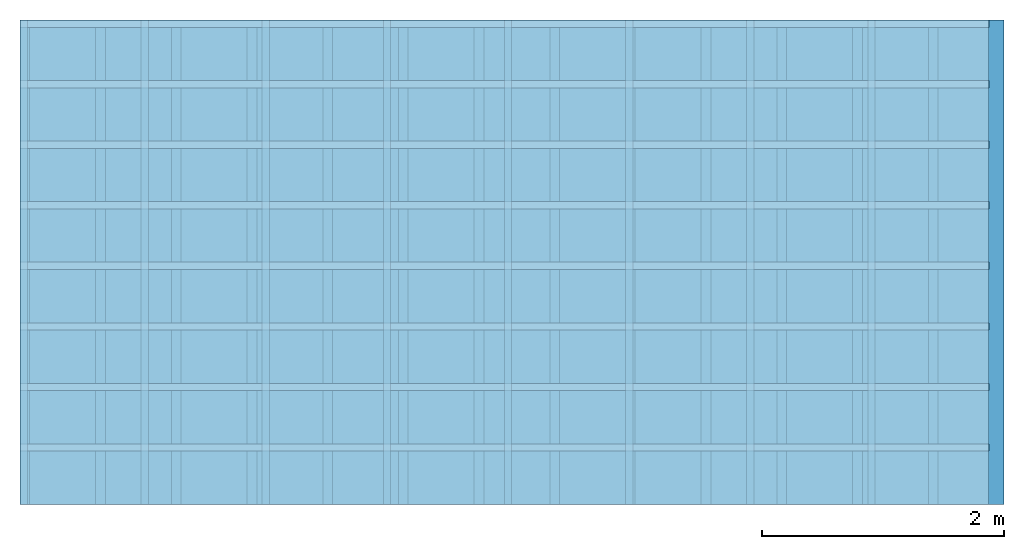
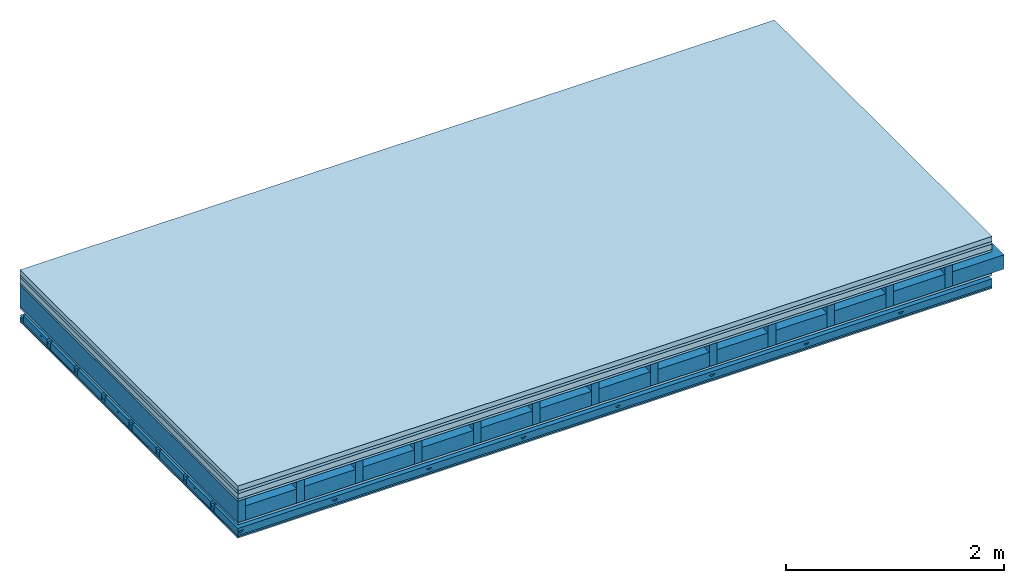
# One storey: 7 plates, 5 members, 1 element without a shape of its own.
"""IFC4 building model written with IfcOpenShell, lengths in metres."""

from ifc_helpers import new_model, si_unit, derived_unit, direction, frame, frame_2d, origin, origin_with_axes, place, context, project, spatial, polyline, rectangle, outline, extrude, material, layer, layer_set, type_object, element, aggregate, save


model = new_model("IFC4")

# Units and contexts
plan_context = context("Plan", 3, precision=1e-05, world=origin(), true_north=direction((0.0, 1.0)))
model_context = context("Model", 3, precision=1e-05, world=origin(), true_north=direction((0.0, 1.0)))
ifc_project = project(units=[si_unit("LENGTHUNIT", "METRE"), derived_unit("SOUNDPRESSUREUNIT", [(si_unit("PRESSUREUNIT", "PASCAL", prefix="MICRO"), 0)]), si_unit("ENERGYUNIT", "JOULE", prefix="MEGA"), si_unit("MASSUNIT", "GRAM", prefix="KILO"), derived_unit("THERMALTRANSMITTANCEUNIT", [(si_unit("POWERUNIT", "WATT"), 1), (si_unit("AREAUNIT", "SQUARE_METRE"), -1), (si_unit("THERMODYNAMICTEMPERATUREUNIT", "KELVIN"), -1)]), derived_unit("AREADENSITYUNIT", [(si_unit("MASSUNIT", "GRAM", prefix="KILO"), 1), (si_unit("AREAUNIT", "SQUARE_METRE"), -1)]), derived_unit("USERDEFINED", [(si_unit("ENERGYUNIT", "JOULE", prefix="MEGA"), 1), (si_unit("AREAUNIT", "SQUARE_METRE"), -1)])], contexts=[plan_context, model_context])

# Site, building, storey
site = spatial("IfcSite", under=ifc_project)
building_placement = place(None, origin())
building = spatial("IfcBuilding", under=site, at=building_placement)
storey_placement = place(building_placement, origin())
storey = spatial("IfcBuildingStorey", under=building, at=storey_placement)

# Slab, members, plates
ifc_material_1 = material(Category="04.005")
ifc_layer_1 = layer(ifc_material_1, 0.055, Name="On-material")
ifc_material_2 = material()
ifc_layer_2 = layer(ifc_material_2, 0.03, Name="Impact sound insulation")
ifc_material_3 = material(Name="Cement panels, glued on sub-floor", Category="02.007")
ifc_layer_3 = layer(ifc_material_3, 0.06, Name="on Supporting structure")
ifc_material_4 = material(Category="07.001")
ifc_layer_4 = layer(ifc_material_4, 0.025, Name="Sub-floor")
ifc_material_5 = material(Name="Rigid, of the art")
ifc_layer_5 = layer(ifc_material_5, 0.0, Name="Bond")
ifc_layer_6 = layer(None, 0.24, Name="Supporting structure")
ifc_layer_7 = layer(ifc_material_5, 0.0, Name="Bond")
ifc_layer_8 = layer(ifc_material_4, 0.025, Name="Lower layer 1")
ifc_layer_9 = layer(None, 0.093, Name="Coupling")
ifc_layer_10 = layer(None, 0.027, Name="Battens / profiles")
ifc_material_6 = material(Name="Plasterboard type A", Category="03.008")
ifc_layer_11 = layer(ifc_material_6, 0.015, Name="Ceiling covering 1st layer")
ifc_layer_12 = layer(ifc_material_6, 0.015, Name="Ceiling covering layer 2")
ifc_material_7 = material(Name="joints", Category="04.017")
ifc_layer_13 = layer(ifc_material_7, 0.0, Name="Surface / treatment")
ifc_layer_set = layer_set([ifc_layer_1, ifc_layer_2, ifc_layer_3, ifc_layer_4, ifc_layer_5, ifc_layer_6, ifc_layer_7, ifc_layer_8, ifc_layer_9, ifc_layer_10, ifc_layer_11, ifc_layer_12, ifc_layer_13])
slab_type = type_object("IfcSlabType", Name="A0585", PredefinedType="NOTDEFINED", material=ifc_layer_set)
slab_placement = place(None, frame((0.0, 0.0, 0.0), z_axis=(0.0, 0.0, -1.0), x_axis=(1.0, 0.0, 0.0)))
slab = element("IfcSlab", 1, at=slab_placement, inside=storey, type_object=slab_type, material=ifc_layer_set, Name="Slab #1")
ifc_material_8 = material()
member_1_placement = place(slab_placement, origin())
member_1 = element("IfcMember", 2, at=member_1_placement, material=ifc_material_8, Name="Supporting structure", context=plan_context, shape_type="SweptSolid", body=[
    extrude(rectangle(XDim=0.08, YDim=0.24, at=frame_2d((0.04, 0.12), x_axis=(1.0, 0.0))), frame((0.0, 4.0, 0.17), z_axis=(0.0, -1.0, 0.0), x_axis=(1.0, 0.0, 0.0)), (0.0, 0.0, 1.0), 4.0),
    extrude(rectangle(XDim=0.08, YDim=0.24, at=frame_2d((0.04, 0.12), x_axis=(1.0, 0.0))), frame((0.625, 4.0, 0.17), z_axis=(0.0, -1.0, 0.0), x_axis=(1.0, 0.0, 0.0)), (0.0, 0.0, 1.0), 4.0),
    extrude(rectangle(XDim=0.08, YDim=0.24, at=frame_2d((0.04, 0.12), x_axis=(1.0, 0.0))), frame((1.25, 4.0, 0.17), z_axis=(0.0, -1.0, 0.0), x_axis=(1.0, 0.0, 0.0)), (0.0, 0.0, 1.0), 4.0),
    extrude(rectangle(XDim=0.08, YDim=0.24, at=frame_2d((0.04, 0.12), x_axis=(1.0, 0.0))), frame((1.875, 4.0, 0.17), z_axis=(0.0, -1.0, 0.0), x_axis=(1.0, 0.0, 0.0)), (0.0, 0.0, 1.0), 4.0),
    extrude(rectangle(XDim=0.08, YDim=0.24, at=frame_2d((0.04, 0.12), x_axis=(1.0, 0.0))), frame((2.5, 4.0, 0.17), z_axis=(0.0, -1.0, 0.0), x_axis=(1.0, 0.0, 0.0)), (0.0, 0.0, 1.0), 4.0),
    extrude(rectangle(XDim=0.08, YDim=0.24, at=frame_2d((0.04, 0.12), x_axis=(1.0, 0.0))), frame((3.125, 4.0, 0.17), z_axis=(0.0, -1.0, 0.0), x_axis=(1.0, 0.0, 0.0)), (0.0, 0.0, 1.0), 4.0),
    extrude(rectangle(XDim=0.08, YDim=0.24, at=frame_2d((0.04, 0.12), x_axis=(1.0, 0.0))), frame((3.75, 4.0, 0.17), z_axis=(0.0, -1.0, 0.0), x_axis=(1.0, 0.0, 0.0)), (0.0, 0.0, 1.0), 4.0),
    extrude(rectangle(XDim=0.08, YDim=0.24, at=frame_2d((0.04, 0.12), x_axis=(1.0, 0.0))), frame((4.375, 4.0, 0.17), z_axis=(0.0, -1.0, 0.0), x_axis=(1.0, 0.0, 0.0)), (0.0, 0.0, 1.0), 4.0),
    extrude(rectangle(XDim=0.08, YDim=0.24, at=frame_2d((0.04, 0.12), x_axis=(1.0, 0.0))), frame((5.0, 4.0, 0.17), z_axis=(0.0, -1.0, 0.0), x_axis=(1.0, 0.0, 0.0)), (0.0, 0.0, 1.0), 4.0),
    extrude(rectangle(XDim=0.08, YDim=0.24, at=frame_2d((0.04, 0.12), x_axis=(1.0, 0.0))), frame((5.625, 4.0, 0.17), z_axis=(0.0, -1.0, 0.0), x_axis=(1.0, 0.0, 0.0)), (0.0, 0.0, 1.0), 4.0),
    extrude(rectangle(XDim=0.08, YDim=0.24, at=frame_2d((0.04, 0.12), x_axis=(1.0, 0.0))), frame((6.25, 4.0, 0.17), z_axis=(0.0, -1.0, 0.0), x_axis=(1.0, 0.0, 0.0)), (0.0, 0.0, 1.0), 4.0),
    extrude(rectangle(XDim=0.08, YDim=0.24, at=frame_2d((0.04, 0.12), x_axis=(1.0, 0.0))), frame((6.875, 4.0, 0.17), z_axis=(0.0, -1.0, 0.0), x_axis=(1.0, 0.0, 0.0)), (0.0, 0.0, 1.0), 4.0),
    extrude(rectangle(XDim=0.08, YDim=0.24, at=frame_2d((0.04, 0.12), x_axis=(1.0, 0.0))), frame((7.5, 4.0, 0.17), z_axis=(0.0, -1.0, 0.0), x_axis=(1.0, 0.0, 0.0)), (0.0, 0.0, 1.0), 4.0),
])
ifc_material_9 = material()
member_2_placement = place(slab_placement, origin())
member_2 = element("IfcMember", 3, at=member_2_placement, material=ifc_material_9, Name="Cavity", context=plan_context, shape_type="SweptSolid", body=[
    extrude(rectangle(XDim=0.545, YDim=0.16, at=frame_2d((0.2725, 0.08), x_axis=(1.0, 0.0))), frame((0.08, 4.0, 0.25), z_axis=(0.0, -1.0, 0.0), x_axis=(1.0, 0.0, 0.0)), (0.0, 0.0, 1.0), 4.0),
    extrude(rectangle(XDim=0.545, YDim=0.16, at=frame_2d((0.2725, 0.08), x_axis=(1.0, 0.0))), frame((0.705, 4.0, 0.25), z_axis=(0.0, -1.0, 0.0), x_axis=(1.0, 0.0, 0.0)), (0.0, 0.0, 1.0), 4.0),
    extrude(rectangle(XDim=0.545, YDim=0.16, at=frame_2d((0.2725, 0.08), x_axis=(1.0, 0.0))), frame((1.33, 4.0, 0.25), z_axis=(0.0, -1.0, 0.0), x_axis=(1.0, 0.0, 0.0)), (0.0, 0.0, 1.0), 4.0),
    extrude(rectangle(XDim=0.545, YDim=0.16, at=frame_2d((0.2725, 0.08), x_axis=(1.0, 0.0))), frame((1.955, 4.0, 0.25), z_axis=(0.0, -1.0, 0.0), x_axis=(1.0, 0.0, 0.0)), (0.0, 0.0, 1.0), 4.0),
    extrude(rectangle(XDim=0.545, YDim=0.16, at=frame_2d((0.2725, 0.08), x_axis=(1.0, 0.0))), frame((2.58, 4.0, 0.25), z_axis=(0.0, -1.0, 0.0), x_axis=(1.0, 0.0, 0.0)), (0.0, 0.0, 1.0), 4.0),
    extrude(rectangle(XDim=0.545, YDim=0.16, at=frame_2d((0.2725, 0.08), x_axis=(1.0, 0.0))), frame((3.205, 4.0, 0.25), z_axis=(0.0, -1.0, 0.0), x_axis=(1.0, 0.0, 0.0)), (0.0, 0.0, 1.0), 4.0),
    extrude(rectangle(XDim=0.545, YDim=0.16, at=frame_2d((0.2725, 0.08), x_axis=(1.0, 0.0))), frame((3.83, 4.0, 0.25), z_axis=(0.0, -1.0, 0.0), x_axis=(1.0, 0.0, 0.0)), (0.0, 0.0, 1.0), 4.0),
    extrude(rectangle(XDim=0.545, YDim=0.16, at=frame_2d((0.2725, 0.08), x_axis=(1.0, 0.0))), frame((4.455, 4.0, 0.25), z_axis=(0.0, -1.0, 0.0), x_axis=(1.0, 0.0, 0.0)), (0.0, 0.0, 1.0), 4.0),
    extrude(rectangle(XDim=0.545, YDim=0.16, at=frame_2d((0.2725, 0.08), x_axis=(1.0, 0.0))), frame((5.08, 4.0, 0.25), z_axis=(0.0, -1.0, 0.0), x_axis=(1.0, 0.0, 0.0)), (0.0, 0.0, 1.0), 4.0),
    extrude(rectangle(XDim=0.545, YDim=0.16, at=frame_2d((0.2725, 0.08), x_axis=(1.0, 0.0))), frame((5.705, 4.0, 0.25), z_axis=(0.0, -1.0, 0.0), x_axis=(1.0, 0.0, 0.0)), (0.0, 0.0, 1.0), 4.0),
    extrude(rectangle(XDim=0.545, YDim=0.16, at=frame_2d((0.2725, 0.08), x_axis=(1.0, 0.0))), frame((6.33, 4.0, 0.25), z_axis=(0.0, -1.0, 0.0), x_axis=(1.0, 0.0, 0.0)), (0.0, 0.0, 1.0), 4.0),
    extrude(rectangle(XDim=0.545, YDim=0.16, at=frame_2d((0.2725, 0.08), x_axis=(1.0, 0.0))), frame((6.955, 4.0, 0.25), z_axis=(0.0, -1.0, 0.0), x_axis=(1.0, 0.0, 0.0)), (0.0, 0.0, 1.0), 4.0),
    extrude(rectangle(XDim=0.545, YDim=0.16, at=frame_2d((0.2725, 0.08), x_axis=(1.0, 0.0))), frame((7.58, 4.0, 0.25), z_axis=(0.0, -1.0, 0.0), x_axis=(1.0, 0.0, 0.0)), (0.0, 0.0, 1.0), 4.0),
])
ifc_material_10 = material()
member_3_placement = place(slab_placement, origin())
member_3 = element("IfcMember", 4, at=member_3_placement, material=ifc_material_10, Name="Coupling", context=plan_context, shape_type="SweptSolid", body=[
    extrude(outline(polyline([(0.0, 0.0), (0.06, 0.0), (0.04, 0.02), (0.02, 0.02), (0.0, 0.0)])), frame((0.0, 4.0, 0.508), z_axis=(0.0, -1.0, 0.0), x_axis=(1.0, 0.0, 0.0)), (0.0, 0.0, 1.0), 4.0),
    extrude(outline(polyline([(0.0, 0.0), (0.06, 0.0), (0.04, 0.02), (0.02, 0.02), (0.0, 0.0)])), frame((1.0, 4.0, 0.508), z_axis=(0.0, -1.0, 0.0), x_axis=(1.0, 0.0, 0.0)), (0.0, 0.0, 1.0), 4.0),
    extrude(outline(polyline([(0.0, 0.0), (0.06, 0.0), (0.04, 0.02), (0.02, 0.02), (0.0, 0.0)])), frame((2.0, 4.0, 0.508), z_axis=(0.0, -1.0, 0.0), x_axis=(1.0, 0.0, 0.0)), (0.0, 0.0, 1.0), 4.0),
    extrude(outline(polyline([(0.0, 0.0), (0.06, 0.0), (0.04, 0.02), (0.02, 0.02), (0.0, 0.0)])), frame((3.0, 4.0, 0.508), z_axis=(0.0, -1.0, 0.0), x_axis=(1.0, 0.0, 0.0)), (0.0, 0.0, 1.0), 4.0),
    extrude(outline(polyline([(0.0, 0.0), (0.06, 0.0), (0.04, 0.02), (0.02, 0.02), (0.0, 0.0)])), frame((4.0, 4.0, 0.508), z_axis=(0.0, -1.0, 0.0), x_axis=(1.0, 0.0, 0.0)), (0.0, 0.0, 1.0), 4.0),
    extrude(outline(polyline([(0.0, 0.0), (0.06, 0.0), (0.04, 0.02), (0.02, 0.02), (0.0, 0.0)])), frame((5.0, 4.0, 0.508), z_axis=(0.0, -1.0, 0.0), x_axis=(1.0, 0.0, 0.0)), (0.0, 0.0, 1.0), 4.0),
    extrude(outline(polyline([(0.0, 0.0), (0.06, 0.0), (0.04, 0.02), (0.02, 0.02), (0.0, 0.0)])), frame((6.0, 4.0, 0.508), z_axis=(0.0, -1.0, 0.0), x_axis=(1.0, 0.0, 0.0)), (0.0, 0.0, 1.0), 4.0),
    extrude(outline(polyline([(0.0, 0.0), (0.06, 0.0), (0.04, 0.02), (0.02, 0.02), (0.0, 0.0)])), frame((7.0, 4.0, 0.508), z_axis=(0.0, -1.0, 0.0), x_axis=(1.0, 0.0, 0.0)), (0.0, 0.0, 1.0), 4.0),
])
ifc_material_11 = material()
member_4_placement = place(slab_placement, origin())
member_4 = element("IfcMember", 5, at=member_4_placement, material=ifc_material_11, Name="Battens / profiles", context=plan_context, shape_type="SweptSolid", body=[
    extrude(rectangle(XDim=0.06, YDim=0.027, at=frame_2d((0.03, 0.0135), x_axis=(1.0, 0.0))), frame((0.0, 0.0, 0.528), z_axis=(1.0, 0.0, 0.0), x_axis=(0.0, 1.0, 0.0)), (0.0, 0.0, 1.0), 8.0),
    extrude(rectangle(XDim=0.06, YDim=0.027, at=frame_2d((0.03, 0.0135), x_axis=(1.0, 0.0))), frame((0.0, 0.5, 0.528), z_axis=(1.0, 0.0, 0.0), x_axis=(0.0, 1.0, 0.0)), (0.0, 0.0, 1.0), 8.0),
    extrude(rectangle(XDim=0.06, YDim=0.027, at=frame_2d((0.03, 0.0135), x_axis=(1.0, 0.0))), frame((0.0, 1.0, 0.528), z_axis=(1.0, 0.0, 0.0), x_axis=(0.0, 1.0, 0.0)), (0.0, 0.0, 1.0), 8.0),
    extrude(rectangle(XDim=0.06, YDim=0.027, at=frame_2d((0.03, 0.0135), x_axis=(1.0, 0.0))), frame((0.0, 1.5, 0.528), z_axis=(1.0, 0.0, 0.0), x_axis=(0.0, 1.0, 0.0)), (0.0, 0.0, 1.0), 8.0),
    extrude(rectangle(XDim=0.06, YDim=0.027, at=frame_2d((0.03, 0.0135), x_axis=(1.0, 0.0))), frame((0.0, 2.0, 0.528), z_axis=(1.0, 0.0, 0.0), x_axis=(0.0, 1.0, 0.0)), (0.0, 0.0, 1.0), 8.0),
    extrude(rectangle(XDim=0.06, YDim=0.027, at=frame_2d((0.03, 0.0135), x_axis=(1.0, 0.0))), frame((0.0, 2.5, 0.528), z_axis=(1.0, 0.0, 0.0), x_axis=(0.0, 1.0, 0.0)), (0.0, 0.0, 1.0), 8.0),
    extrude(rectangle(XDim=0.06, YDim=0.027, at=frame_2d((0.03, 0.0135), x_axis=(1.0, 0.0))), frame((0.0, 3.0, 0.528), z_axis=(1.0, 0.0, 0.0), x_axis=(0.0, 1.0, 0.0)), (0.0, 0.0, 1.0), 8.0),
    extrude(rectangle(XDim=0.06, YDim=0.027, at=frame_2d((0.03, 0.0135), x_axis=(1.0, 0.0))), frame((0.0, 3.5, 0.528), z_axis=(1.0, 0.0, 0.0), x_axis=(0.0, 1.0, 0.0)), (0.0, 0.0, 1.0), 8.0),
])
member_5_placement = place(slab_placement, origin())
member_5 = element("IfcMember", 6, at=member_5_placement, material=ifc_material_9, Name="Cavity", context=plan_context, shape_type="SweptSolid", body=[
    extrude(rectangle(XDim=0.44, YDim=0.08, at=frame_2d((0.22, 0.04), x_axis=(1.0, 0.0))), frame((0.0, 0.06, 0.475), z_axis=(1.0, 0.0, 0.0), x_axis=(0.0, 1.0, 0.0)), (0.0, 0.0, 1.0), 8.0),
    extrude(rectangle(XDim=0.44, YDim=0.08, at=frame_2d((0.22, 0.04), x_axis=(1.0, 0.0))), frame((0.0, 0.56, 0.475), z_axis=(1.0, 0.0, 0.0), x_axis=(0.0, 1.0, 0.0)), (0.0, 0.0, 1.0), 8.0),
    extrude(rectangle(XDim=0.44, YDim=0.08, at=frame_2d((0.22, 0.04), x_axis=(1.0, 0.0))), frame((0.0, 1.06, 0.475), z_axis=(1.0, 0.0, 0.0), x_axis=(0.0, 1.0, 0.0)), (0.0, 0.0, 1.0), 8.0),
    extrude(rectangle(XDim=0.44, YDim=0.08, at=frame_2d((0.22, 0.04), x_axis=(1.0, 0.0))), frame((0.0, 1.56, 0.475), z_axis=(1.0, 0.0, 0.0), x_axis=(0.0, 1.0, 0.0)), (0.0, 0.0, 1.0), 8.0),
    extrude(rectangle(XDim=0.44, YDim=0.08, at=frame_2d((0.22, 0.04), x_axis=(1.0, 0.0))), frame((0.0, 2.06, 0.475), z_axis=(1.0, 0.0, 0.0), x_axis=(0.0, 1.0, 0.0)), (0.0, 0.0, 1.0), 8.0),
    extrude(rectangle(XDim=0.44, YDim=0.08, at=frame_2d((0.22, 0.04), x_axis=(1.0, 0.0))), frame((0.0, 2.56, 0.475), z_axis=(1.0, 0.0, 0.0), x_axis=(0.0, 1.0, 0.0)), (0.0, 0.0, 1.0), 8.0),
    extrude(rectangle(XDim=0.44, YDim=0.08, at=frame_2d((0.22, 0.04), x_axis=(1.0, 0.0))), frame((0.0, 3.06, 0.475), z_axis=(1.0, 0.0, 0.0), x_axis=(0.0, 1.0, 0.0)), (0.0, 0.0, 1.0), 8.0),
    extrude(rectangle(XDim=0.44, YDim=0.08, at=frame_2d((0.22, 0.04), x_axis=(1.0, 0.0))), frame((0.0, 3.56, 0.475), z_axis=(1.0, 0.0, 0.0), x_axis=(0.0, 1.0, 0.0)), (0.0, 0.0, 1.0), 8.0),
])
plate_1_placement = place(slab_placement, origin())
plate_1 = element("IfcPlate", 7, at=plate_1_placement, material=ifc_material_1, Name="On-material", context=plan_context, shape_type="SweptSolid", body=[
    extrude(rectangle(XDim=8.0, YDim=4.0, at=frame_2d((4.0, 2.0), x_axis=(1.0, 0.0))), origin_with_axes(), (0.0, 0.0, 1.0), 0.055),
])
plate_2_placement = place(slab_placement, origin())
plate_2 = element("IfcPlate", 8, at=plate_2_placement, material=ifc_material_2, Name="Impact sound insulation", context=plan_context, shape_type="SweptSolid", body=[
    extrude(rectangle(XDim=8.0, YDim=4.0, at=frame_2d((4.0, 2.0), x_axis=(1.0, 0.0))), frame((0.0, 0.0, 0.055), z_axis=(0.0, 0.0, 1.0), x_axis=(1.0, 0.0, 0.0)), (0.0, 0.0, 1.0), 0.03),
])
plate_3_placement = place(slab_placement, origin())
plate_3 = element("IfcPlate", 9, at=plate_3_placement, material=ifc_material_3, Name="on Supporting structure", context=plan_context, shape_type="SweptSolid", body=[
    extrude(rectangle(XDim=8.0, YDim=4.0, at=frame_2d((4.0, 2.0), x_axis=(1.0, 0.0))), frame((0.0, 0.0, 0.085), z_axis=(0.0, 0.0, 1.0), x_axis=(1.0, 0.0, 0.0)), (0.0, 0.0, 1.0), 0.06),
])
plate_4_placement = place(slab_placement, origin())
plate_4 = element("IfcPlate", 10, at=plate_4_placement, material=ifc_material_4, Name="Sub-floor", context=plan_context, shape_type="SweptSolid", body=[
    extrude(rectangle(XDim=8.0, YDim=4.0, at=frame_2d((4.0, 2.0), x_axis=(1.0, 0.0))), frame((0.0, 0.0, 0.145), z_axis=(0.0, 0.0, 1.0), x_axis=(1.0, 0.0, 0.0)), (0.0, 0.0, 1.0), 0.025),
])
plate_5_placement = place(slab_placement, origin())
plate_5 = element("IfcPlate", 11, at=plate_5_placement, material=ifc_material_4, Name="Lower layer 1", context=plan_context, shape_type="SweptSolid", body=[
    extrude(rectangle(XDim=8.0, YDim=4.0, at=frame_2d((4.0, 2.0), x_axis=(1.0, 0.0))), frame((0.0, 0.0, 0.41), z_axis=(0.0, 0.0, 1.0), x_axis=(1.0, 0.0, 0.0)), (0.0, 0.0, 1.0), 0.025),
])
plate_6_placement = place(slab_placement, origin())
plate_6 = element("IfcPlate", 12, at=plate_6_placement, material=ifc_material_6, Name="Ceiling covering 1st layer", context=plan_context, shape_type="SweptSolid", body=[
    extrude(rectangle(XDim=8.0, YDim=4.0, at=frame_2d((4.0, 2.0), x_axis=(1.0, 0.0))), frame((0.0, 0.0, 0.555), z_axis=(0.0, 0.0, 1.0), x_axis=(1.0, 0.0, 0.0)), (0.0, 0.0, 1.0), 0.015),
])
plate_7_placement = place(slab_placement, origin())
plate_7 = element("IfcPlate", 13, at=plate_7_placement, material=ifc_material_6, Name="Ceiling covering layer 2", context=plan_context, shape_type="SweptSolid", body=[
    extrude(rectangle(XDim=8.0, YDim=4.0, at=frame_2d((4.0, 2.0), x_axis=(1.0, 0.0))), frame((0.0, 0.0, 0.57), z_axis=(0.0, 0.0, 1.0), x_axis=(1.0, 0.0, 0.0)), (0.0, 0.0, 1.0), 0.015),
])
aggregate(slab, [plate_1, plate_2, plate_3, plate_4, member_1, member_2, plate_5, member_3, member_4, member_5, plate_6, plate_7])

save(model, "model.ifc")
